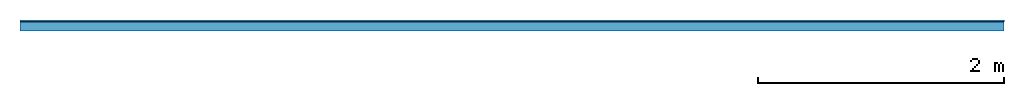
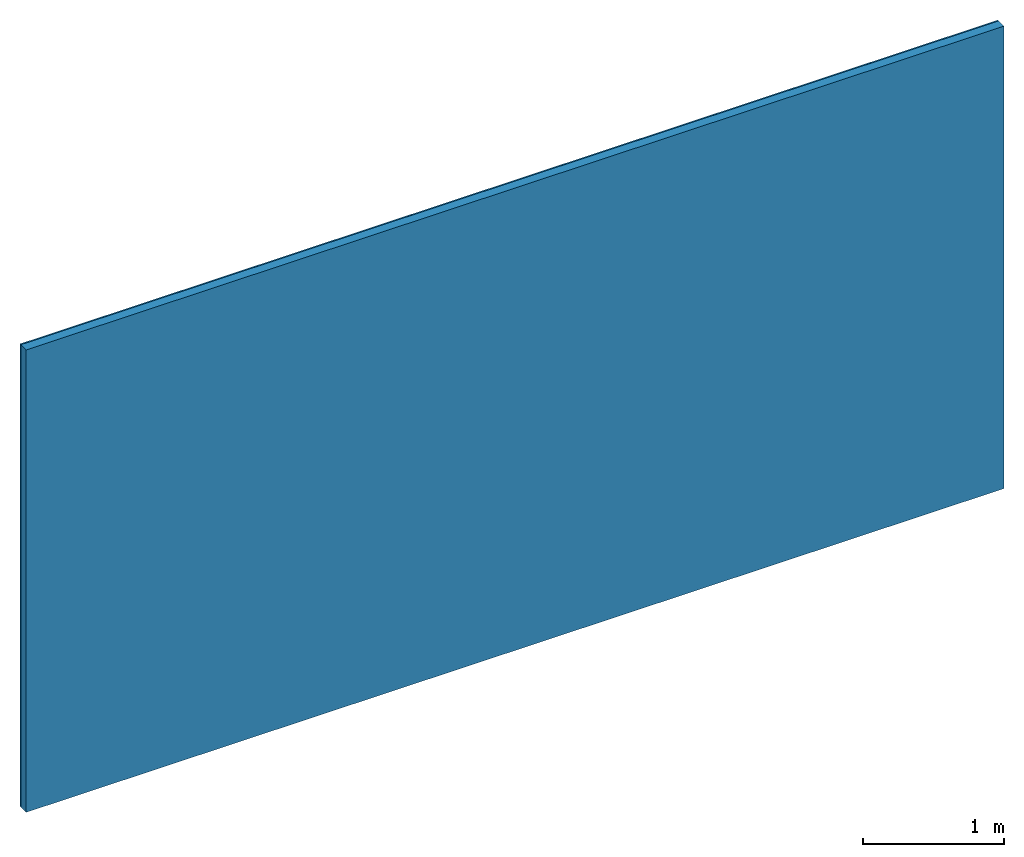
# One storey: 1 member, 1 plate, 1 element without a shape of its own.
"""IFC4 building model written with IfcOpenShell, lengths in metres."""

from ifc_helpers import new_model, si_unit, derived_unit, direction, frame, frame_2d, origin, origin_with_axes, place, context, project, spatial, rectangle, extrude, material, layer, layer_set, type_object, element, aggregate, save


model = new_model("IFC4")

# Units and contexts
plan_context = context("Plan", 3, precision=1e-05, world=origin(), true_north=direction((0.0, 1.0)))
model_context = context("Model", 3, precision=1e-05, world=origin(), true_north=direction((0.0, 1.0)))
ifc_project = project(units=[si_unit("LENGTHUNIT", "METRE"), derived_unit("SOUNDPRESSUREUNIT", [(si_unit("PRESSUREUNIT", "PASCAL", prefix="MICRO"), 0)]), si_unit("ENERGYUNIT", "JOULE", prefix="MEGA"), si_unit("MASSUNIT", "GRAM", prefix="KILO"), derived_unit("THERMALTRANSMITTANCEUNIT", [(si_unit("POWERUNIT", "WATT"), 1), (si_unit("AREAUNIT", "SQUARE_METRE"), -1), (si_unit("THERMODYNAMICTEMPERATUREUNIT", "KELVIN"), -1)]), derived_unit("AREADENSITYUNIT", [(si_unit("MASSUNIT", "GRAM", prefix="KILO"), 1), (si_unit("AREAUNIT", "SQUARE_METRE"), -1)]), derived_unit("USERDEFINED", [(si_unit("ENERGYUNIT", "JOULE", prefix="MEGA"), 1), (si_unit("AREAUNIT", "SQUARE_METRE"), -1)])], contexts=[plan_context, model_context])

# Site, building, storey
site = spatial("IfcSite", under=ifc_project)
building_placement = place(None, origin())
building = spatial("IfcBuilding", under=site, at=building_placement)
storey_placement = place(building_placement, origin())
storey = spatial("IfcBuildingStorey", under=building, at=storey_placement)

# Wall, member, plate
ifc_material_1 = material(Name="joints", Category="04.017")
ifc_layer_1 = layer(ifc_material_1, 0.0, Name="Surface")
ifc_material_2 = material(Name="Rigidur H", Category="03.007")
ifc_layer_2 = layer(ifc_material_2, 0.0125, Name="1st layer")
ifc_material_3 = material(Name="of the art")
ifc_layer_3 = layer(ifc_material_3, 0.0, Name="Bond")
ifc_layer_4 = layer(None, 0.075, Name="Support")
ifc_layer_set = layer_set([ifc_layer_1, ifc_layer_2, ifc_layer_3, ifc_layer_4])
wall_type = type_object("IfcWallType", Name="C0466", PredefinedType="NOTDEFINED", material=ifc_layer_set)
wall_placement = place(None, frame((0.0, 0.0, 0.0), z_axis=(0.0, -1.0, 0.0), x_axis=(1.0, 0.0, 0.0)))
wall = element("IfcWall", 1, at=wall_placement, inside=storey, type_object=wall_type, material=ifc_layer_set, Name="Wall #1")
ifc_material_4 = material(Name="OSB")
member_placement = place(wall_placement, origin())
member = element("IfcMember", 2, at=member_placement, material=ifc_material_4, Name="Support", context=plan_context, shape_type="SweptSolid", body=[
    extrude(rectangle(XDim=1.0, YDim=0.075, at=frame_2d((0.5, 0.0375), x_axis=(1.0, 0.0))), frame((0.0, 4.0, 0.0125), z_axis=(0.0, -1.0, 0.0), x_axis=(1.0, 0.0, 0.0)), (0.0, 0.0, 1.0), 4.0),
    extrude(rectangle(XDim=1.0, YDim=0.075, at=frame_2d((0.5, 0.0375), x_axis=(1.0, 0.0))), frame((1.0, 4.0, 0.0125), z_axis=(0.0, -1.0, 0.0), x_axis=(1.0, 0.0, 0.0)), (0.0, 0.0, 1.0), 4.0),
    extrude(rectangle(XDim=1.0, YDim=0.075, at=frame_2d((0.5, 0.0375), x_axis=(1.0, 0.0))), frame((2.0, 4.0, 0.0125), z_axis=(0.0, -1.0, 0.0), x_axis=(1.0, 0.0, 0.0)), (0.0, 0.0, 1.0), 4.0),
    extrude(rectangle(XDim=1.0, YDim=0.075, at=frame_2d((0.5, 0.0375), x_axis=(1.0, 0.0))), frame((3.0, 4.0, 0.0125), z_axis=(0.0, -1.0, 0.0), x_axis=(1.0, 0.0, 0.0)), (0.0, 0.0, 1.0), 4.0),
    extrude(rectangle(XDim=1.0, YDim=0.075, at=frame_2d((0.5, 0.0375), x_axis=(1.0, 0.0))), frame((4.0, 4.0, 0.0125), z_axis=(0.0, -1.0, 0.0), x_axis=(1.0, 0.0, 0.0)), (0.0, 0.0, 1.0), 4.0),
    extrude(rectangle(XDim=1.0, YDim=0.075, at=frame_2d((0.5, 0.0375), x_axis=(1.0, 0.0))), frame((5.0, 4.0, 0.0125), z_axis=(0.0, -1.0, 0.0), x_axis=(1.0, 0.0, 0.0)), (0.0, 0.0, 1.0), 4.0),
    extrude(rectangle(XDim=1.0, YDim=0.075, at=frame_2d((0.5, 0.0375), x_axis=(1.0, 0.0))), frame((6.0, 4.0, 0.0125), z_axis=(0.0, -1.0, 0.0), x_axis=(1.0, 0.0, 0.0)), (0.0, 0.0, 1.0), 4.0),
    extrude(rectangle(XDim=1.0, YDim=0.075, at=frame_2d((0.5, 0.0375), x_axis=(1.0, 0.0))), frame((7.0, 4.0, 0.0125), z_axis=(0.0, -1.0, 0.0), x_axis=(1.0, 0.0, 0.0)), (0.0, 0.0, 1.0), 4.0),
])
plate_placement = place(wall_placement, origin())
plate = element("IfcPlate", 3, at=plate_placement, material=ifc_material_2, Name="1st layer", context=plan_context, shape_type="SweptSolid", body=[
    extrude(rectangle(XDim=8.0, YDim=4.0, at=frame_2d((4.0, 2.0), x_axis=(1.0, 0.0))), origin_with_axes(), (0.0, 0.0, 1.0), 0.0125),
])
aggregate(wall, [plate, member])

save(model, "model.ifc")
